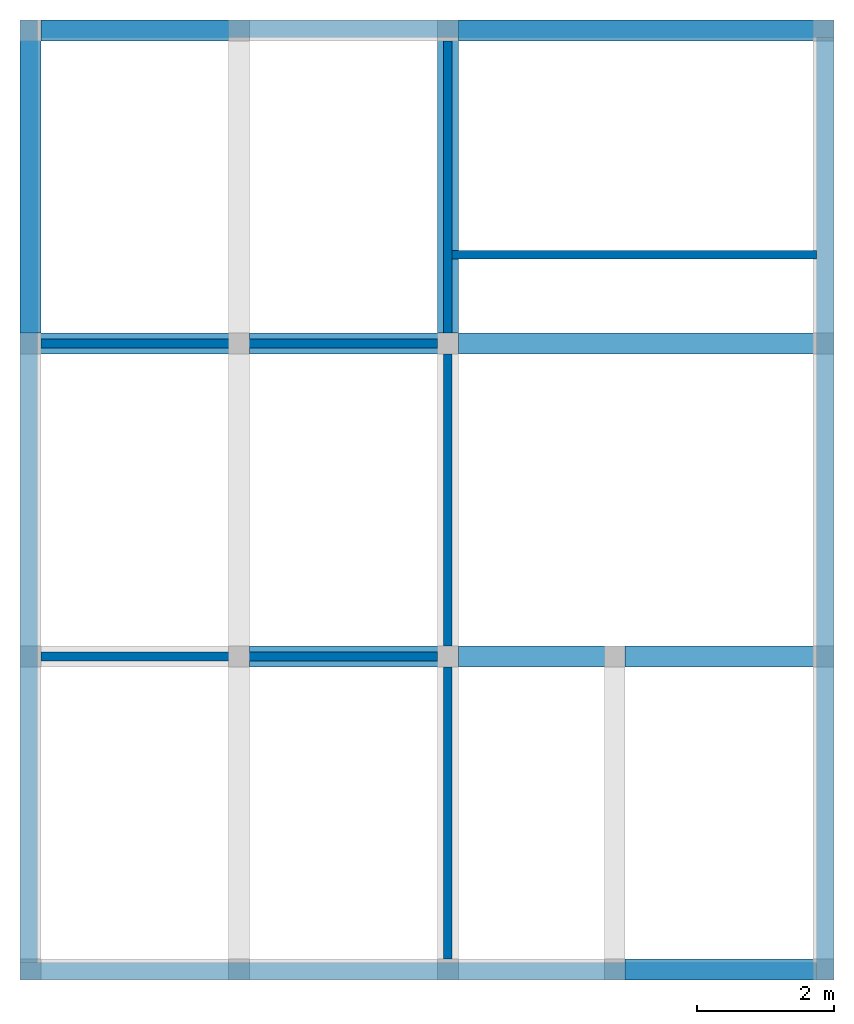
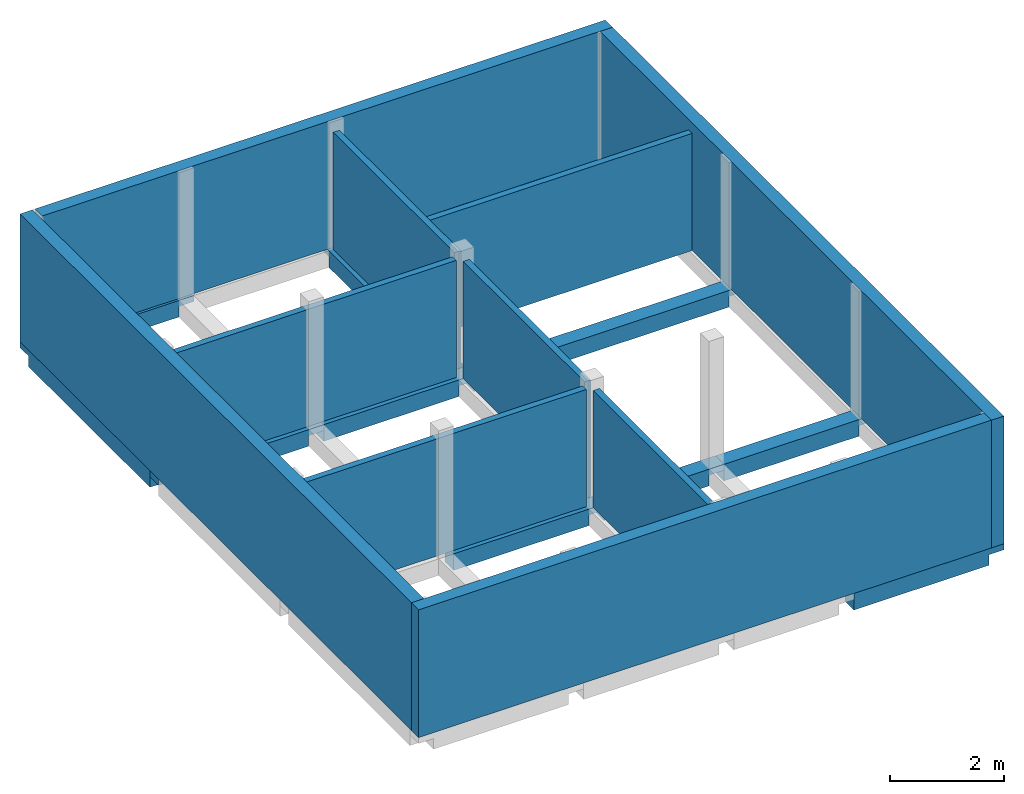
# One storey, part 2 of 2: 11 beams, 10 walls.
"""IFC2X3 building model written with IfcOpenShell, lengths in feet."""

from ifc_helpers import new_model, entity, si_unit, converted_unit, derived_unit, direction, frame, frame_2d, origin, place, context, subcontext, project, spatial, rectangle, extrude, faceted_brep, material, layer, layer_set, layer_usage, type_object, element, save


model = new_model("IFC2X3")

# Units and contexts
model_context = context("Model", 3, precision=0.0001, world=origin(), true_north=direction((6.123031769111886e-17, 1.0)))
body_context = subcontext(model_context, "Body", "Model", "MODEL_VIEW")
ifc_project = project(units=[converted_unit("LENGTHUNIT", "FOOT", entity("IfcLengthMeasure", 0.3048), si_unit("LENGTHUNIT", "METRE"), dimensions=[1, 0, 0, 0, 0, 0, 0]), converted_unit("AREAUNIT", "SQUARE FOOT", entity("IfcAreaMeasure", 0.09290304), si_unit("AREAUNIT", "SQUARE_METRE"), dimensions=[2, 0, 0, 0, 0, 0, 0]), converted_unit("VOLUMEUNIT", "CUBIC FOOT", entity("IfcVolumeMeasure", 0.028316846592000004), si_unit("VOLUMEUNIT", "CUBIC_METRE"), dimensions=[3, 0, 0, 0, 0, 0, 0]), converted_unit("PLANEANGLEUNIT", "DEGREE", entity("IfcPlaneAngleMeasure", 0.017453292519943278), si_unit("PLANEANGLEUNIT", "RADIAN"), dimensions=[0, 0, 0, 0, 0, 0, 0]), si_unit("MASSUNIT", "GRAM", prefix="KILO"), derived_unit("MASSDENSITYUNIT", [(si_unit("MASSUNIT", "GRAM", prefix="KILO"), 1), (si_unit("LENGTHUNIT", "METRE"), -3)]), derived_unit("IONCONCENTRATIONUNIT", [(si_unit("MASSUNIT", "GRAM", prefix="KILO"), 1), (si_unit("LENGTHUNIT", "METRE"), -3)]), derived_unit("MOMENTOFINERTIAUNIT", [(si_unit("LENGTHUNIT", "METRE"), 4)]), si_unit("TIMEUNIT", "SECOND"), si_unit("FREQUENCYUNIT", "HERTZ"), si_unit("THERMODYNAMICTEMPERATUREUNIT", "DEGREE_CELSIUS"), derived_unit("THERMALTRANSMITTANCEUNIT", [(si_unit("MASSUNIT", "GRAM", prefix="KILO"), 1), (si_unit("THERMODYNAMICTEMPERATUREUNIT", "KELVIN"), -1), (si_unit("TIMEUNIT", "SECOND"), -3)]), derived_unit("THERMALCONDUCTANCEUNIT", [(si_unit("MASSUNIT", "GRAM", prefix="KILO"), 1), (si_unit("THERMODYNAMICTEMPERATUREUNIT", "KELVIN"), -1), (si_unit("TIMEUNIT", "SECOND"), -3), (si_unit("LENGTHUNIT", "METRE"), 1)]), derived_unit("VOLUMETRICFLOWRATEUNIT", [(si_unit("LENGTHUNIT", "METRE"), 3), (si_unit("TIMEUNIT", "SECOND"), -1)]), derived_unit("MASSFLOWRATEUNIT", [(si_unit("MASSUNIT", "GRAM", prefix="KILO"), 1), (si_unit("TIMEUNIT", "SECOND"), -1)]), derived_unit("ROTATIONALFREQUENCYUNIT", [(si_unit("TIMEUNIT", "SECOND"), -1)]), si_unit("ELECTRICCURRENTUNIT", "AMPERE"), si_unit("ELECTRICVOLTAGEUNIT", "VOLT"), si_unit("POWERUNIT", "WATT"), converted_unit("FORCEUNIT", "KIP", entity("IfcForceMeasure", 2.088543423315013e-05), si_unit("FORCEUNIT", "NEWTON"), dimensions=[1, 1, -2, 0, 0, 0, 0]), si_unit("ILLUMINANCEUNIT", "LUX"), si_unit("LUMINOUSFLUXUNIT", "LUMEN"), si_unit("LUMINOUSINTENSITYUNIT", "CANDELA"), si_unit("ENERGYUNIT", "JOULE"), derived_unit("USERDEFINED", [(si_unit("MASSUNIT", "GRAM", prefix="KILO"), -1), (si_unit("LENGTHUNIT", "METRE"), -2), (si_unit("TIMEUNIT", "SECOND"), 3), (si_unit("LUMINOUSFLUXUNIT", "LUMEN"), 1)]), derived_unit("USERDEFINED", [(si_unit("MASSUNIT", "GRAM", prefix="KILO"), 1), (si_unit("TIMEUNIT", "SECOND"), -3), (si_unit("LENGTHUNIT", "METRE"), 3), (si_unit("ELECTRICCURRENTUNIT", "AMPERE"), -2)]), derived_unit("SOUNDPOWERUNIT", [(si_unit("MASSUNIT", "GRAM", prefix="KILO"), 1), (si_unit("TIMEUNIT", "SECOND"), -3), (si_unit("LENGTHUNIT", "METRE"), 2)]), derived_unit("SOUNDPRESSUREUNIT", [(si_unit("MASSUNIT", "GRAM", prefix="KILO"), 1), (si_unit("LENGTHUNIT", "METRE"), -1), (si_unit("TIMEUNIT", "SECOND"), -2)]), derived_unit("LINEARVELOCITYUNIT", [(si_unit("LENGTHUNIT", "METRE"), 1), (si_unit("TIMEUNIT", "SECOND"), -1)]), si_unit("PRESSUREUNIT", "PASCAL"), derived_unit("USERDEFINED", [(si_unit("MASSUNIT", "GRAM", prefix="KILO"), 1), (si_unit("LENGTHUNIT", "METRE"), -2), (si_unit("TIMEUNIT", "SECOND"), -2)]), derived_unit("LINEARFORCEUNIT", [(si_unit("MASSUNIT", "GRAM", prefix="KILO"), 1), (si_unit("TIMEUNIT", "SECOND"), -2)]), derived_unit("PLANARFORCEUNIT", [(si_unit("MASSUNIT", "GRAM", prefix="KILO"), 1), (si_unit("LENGTHUNIT", "METRE"), -1), (si_unit("TIMEUNIT", "SECOND"), -2)]), derived_unit("SPECIFICHEATCAPACITYUNIT", [(si_unit("THERMODYNAMICTEMPERATUREUNIT", "KELVIN"), -1), (si_unit("LENGTHUNIT", "METRE"), 2), (si_unit("TIMEUNIT", "SECOND"), -2)]), derived_unit("HEATFLUXDENSITYUNIT", [(si_unit("MASSUNIT", "GRAM", prefix="KILO"), 1), (si_unit("TIMEUNIT", "SECOND"), -3)]), derived_unit("HEATINGVALUEUNIT", [(si_unit("LENGTHUNIT", "METRE"), 2), (si_unit("TIMEUNIT", "SECOND"), -2)]), derived_unit("VAPORPERMEABILITYUNIT", [(si_unit("LENGTHUNIT", "METRE"), -1), (si_unit("TIMEUNIT", "SECOND"), 1)]), derived_unit("DYNAMICVISCOSITYUNIT", [(si_unit("MASSUNIT", "GRAM", prefix="KILO"), 1), (si_unit("TIMEUNIT", "SECOND"), -1), (si_unit("LENGTHUNIT", "METRE"), -1)]), derived_unit("THERMALEXPANSIONCOEFFICIENTUNIT", [(si_unit("THERMODYNAMICTEMPERATUREUNIT", "KELVIN"), -1)]), derived_unit("MODULUSOFELASTICITYUNIT", [(si_unit("MASSUNIT", "GRAM", prefix="KILO"), 1), (si_unit("LENGTHUNIT", "METRE"), -1), (si_unit("TIMEUNIT", "SECOND"), -2)]), derived_unit("ISOTHERMALMOISTURECAPACITYUNIT", [(si_unit("LENGTHUNIT", "METRE"), 3), (si_unit("MASSUNIT", "GRAM", prefix="KILO"), -1)]), derived_unit("MOISTUREDIFFUSIVITYUNIT", [(si_unit("TIMEUNIT", "SECOND"), -1), (si_unit("LENGTHUNIT", "METRE"), 2)]), derived_unit("MASSPERLENGTHUNIT", [(si_unit("MASSUNIT", "GRAM", prefix="KILO"), 1), (si_unit("LENGTHUNIT", "METRE"), -1)]), derived_unit("THERMALRESISTANCEUNIT", [(si_unit("MASSUNIT", "GRAM", prefix="KILO"), -1), (si_unit("TIMEUNIT", "SECOND"), 3), (si_unit("THERMODYNAMICTEMPERATUREUNIT", "KELVIN"), 1)]), derived_unit("ACCELERATIONUNIT", [(si_unit("LENGTHUNIT", "METRE"), 1), (si_unit("TIMEUNIT", "SECOND"), -2)]), derived_unit("ANGULARVELOCITYUNIT", [(si_unit("TIMEUNIT", "SECOND"), -1), (si_unit("PLANEANGLEUNIT", "RADIAN"), 1)]), derived_unit("LINEARSTIFFNESSUNIT", [(si_unit("MASSUNIT", "GRAM", prefix="KILO"), 1), (si_unit("TIMEUNIT", "SECOND"), -2)]), derived_unit("WARPINGCONSTANTUNIT", [(si_unit("LENGTHUNIT", "METRE"), 6)]), derived_unit("LINEARMOMENTUNIT", [(si_unit("MASSUNIT", "GRAM", prefix="KILO"), 1), (si_unit("LENGTHUNIT", "METRE"), 1), (si_unit("TIMEUNIT", "SECOND"), -2)]), derived_unit("TORQUEUNIT", [(si_unit("MASSUNIT", "GRAM", prefix="KILO"), 1), (si_unit("LENGTHUNIT", "METRE"), 2), (si_unit("TIMEUNIT", "SECOND"), -2)])], contexts=[model_context])

# Site, building, storey
site_placement = place(None, origin())
site = spatial("IfcSite", under=ifc_project, at=site_placement, CompositionType="ELEMENT")
building_placement = place(site_placement, origin())
building = spatial("IfcBuilding", under=site, at=building_placement, CompositionType="ELEMENT")
storey_placement = place(building_placement, frame((0.0, 0.0, 9.416666666668288)))
storey = spatial("IfcBuildingStorey", under=building, at=storey_placement, Name="First Floor", CompositionType="ELEMENT", Elevation=9.416666666668288)

# Beams
ifc_material_1 = material(Name="Concrete, Cast-in-Place gray")
beam_type = type_object("IfcBeamType", PredefinedType="NOTDEFINED")
for number, where in (
    (1, (38.37447801916311, -50.34124484724908, -1.1666666666666714)),
    (2, (20.374478019163327, -35.34124484724902, -1.1666666666666714)),
):
    element("IfcBeam", number, at=place(storey_placement, frame(where)), inside=storey, type_object=beam_type, material=ifc_material_1, context=body_context, shape_type="Brep", body=[
        faceted_brep([(10.0, 0.0, 1.1666666666666643), (10.0, 1.0, 1.1666666666666643), (9.0, 1.0, 1.1666666666666643), (0.0, 1.0, 1.1666666666666643), (0.0, 0.0, 1.1666666666666643), (9.0, 0.0, 1.1666666666666643), (0.0, 0.0, 0.7499999999983835), (0.0, 0.0, 0.0), (9.0, 0.0, 0.0), (9.0, 0.0, 0.7499999999983835), (10.0, 0.0, 0.7499999999983835), (0.0, 1.0, 0.0), (9.0, 1.0, 0.0), (10.0, 1.0, 0.7499999999983835), (9.0, 1.0, 0.7499999999983835), (0.0, 1.0, 0.7499999999983835)], [[[0, 1, 2, 3, 4, 5]], [[0, 5, 4, 6, 7, 8, 9, 10]], [[7, 11, 12, 8]], [[3, 2, 1, 13, 14, 12, 11, 15]], [[1, 0, 10, 13]], [[4, 3, 15, 11, 7, 6]], [[14, 9, 8, 12]], [[9, 14, 13, 10]]]),
    ])
beam_1_placement = place(storey_placement, frame((30.37447801916315, -35.34124484724903, -1.1666666666666732)))
element("IfcBeam", 3, at=beam_1_placement, inside=storey, type_object=beam_type, material=ifc_material_1, context=body_context, shape_type="Brep", body=[
    faceted_brep([(8.0, 0.0, 1.166666666666666), (8.0, 1.0, 1.166666666666666), (7.0, 1.0, 1.166666666666666), (0.0, 1.0, 1.166666666666666), (0.0, 0.0, 1.1666666666666679), (7.0, 0.0, 1.1666666666666679), (0.0, 0.0, 0.7499999999983853), (0.0, 0.0, 0.0), (7.0, 0.0, 0.0), (7.0, 0.0, 0.7499999999983853), (8.0, 0.0, 0.7499999999983853), (0.0, 1.0, 0.0), (7.0, 1.0, 0.0), (8.0, 1.0, 0.7499999999983853), (7.0, 1.0, 0.7499999999983853), (0.0, 1.0, 0.7499999999983853)], [[[0, 1, 2, 3, 4, 5]], [[0, 5, 4, 6, 7, 8, 9, 10]], [[7, 11, 12, 8]], [[3, 2, 1, 13, 14, 12, 11, 15]], [[1, 0, 10, 13]], [[4, 3, 15, 11, 7, 6]], [[14, 9, 8, 12]], [[9, 14, 13, 10]]]),
])
beam_2_placement = place(storey_placement, frame((38.37447801916313, -35.34124484724908, -1.1666666666666714)))
element("IfcBeam", 4, at=beam_2_placement, inside=storey, type_object=beam_type, material=ifc_material_1, context=body_context, shape_type="Brep", body=[
    faceted_brep([(10.0, 0.0, 1.1666666666666643), (10.0, 1.0, 1.1666666666666643), (9.0, 1.0, 1.1666666666666643), (0.0, 1.0, 1.1666666666666643), (0.0, 0.0, 1.1666666666666643), (9.0, 0.0, 1.1666666666666643), (0.0, 0.0, 0.7499999999983835), (0.0, 0.0, 0.0), (9.0, 0.0, 0.0), (9.0, 0.0, 0.7499999999983835), (10.0, 0.0, 0.7499999999983835), (0.0, 1.0, 0.0), (9.0, 1.0, 0.0), (10.0, 1.0, 0.7499999999983835), (9.0, 1.0, 0.7499999999983835), (0.0, 1.0, 0.7499999999983835)], [[[0, 1, 2, 3, 4, 5]], [[0, 5, 4, 6, 7, 8, 9, 10]], [[7, 11, 12, 8]], [[3, 2, 1, 13, 14, 12, 11, 15]], [[1, 0, 10, 13]], [[4, 3, 15, 11, 7, 6]], [[14, 9, 8, 12]], [[9, 14, 13, 10]]]),
])
beam_3_placement = place(storey_placement, frame((9.374478019163147, -20.341244847248984, -1.1666666666666714)))
element("IfcBeam", 5, at=beam_3_placement, inside=storey, type_object=beam_type, material=ifc_material_1, context=body_context, shape_type="Brep", body=[
    faceted_brep([(11.0, 0.0, 1.1666666666666643), (11.0, 1.0, 1.1666666666666643), (10.0, 1.0, 1.1666666666666643), (1.0, 1.0, 1.1666666666666643), (0.0, 1.0, 1.1666666666666643), (0.0, 0.0, 1.1666666666666643), (1.0, 0.0, 1.1666666666666643), (10.0, 0.0, 1.1666666666666643), (0.0, 0.0, 0.7499999999983835), (1.0, 0.0, 0.7499999999983835), (1.0, 0.0, 0.0), (10.0, 0.0, 0.0), (10.0, 0.0, 0.7499999999983835), (11.0, 0.0, 0.7499999999983835), (1.0, 1.0, 0.0), (10.0, 1.0, 0.0), (11.0, 1.0, 0.7499999999983835), (10.0, 1.0, 0.7499999999983835), (1.0, 1.0, 0.7499999999983835), (0.0, 1.0, 0.7499999999983835)], [[[0, 1, 2, 3, 4, 5, 6, 7]], [[0, 7, 6, 5, 8, 9, 10, 11, 12, 13]], [[10, 14, 15, 11]], [[4, 3, 2, 1, 16, 17, 15, 14, 18, 19]], [[1, 0, 13, 16]], [[5, 4, 19, 8]], [[9, 18, 14, 10]], [[18, 9, 8, 19]], [[17, 12, 11, 15]], [[12, 17, 16, 13]]]),
])
beam_4_placement = place(storey_placement, frame((20.374478019163355, -20.341244847249012, -1.1666666666666714)))
element("IfcBeam", 6, at=beam_4_placement, inside=storey, type_object=beam_type, material=ifc_material_1, context=body_context, shape_type="Brep", body=[
    faceted_brep([(10.0, 0.0, 1.1666666666666643), (10.0, 1.0, 1.1666666666666643), (9.0, 1.0, 1.1666666666666643), (0.0, 1.0, 1.1666666666666643), (0.0, 0.0, 1.1666666666666643), (9.0, 0.0, 1.1666666666666643), (0.0, 0.0, 0.7499999999983835), (0.0, 0.0, 0.0), (9.0, 0.0, 0.0), (9.0, 0.0, 0.7499999999983835), (10.0, 0.0, 0.7499999999983835), (0.0, 1.0, 0.0), (9.0, 1.0, 0.0), (10.0, 1.0, 0.7499999999983835), (9.0, 1.0, 0.7499999999983835), (0.0, 1.0, 0.7499999999983835)], [[[0, 1, 2, 3, 4, 5]], [[0, 5, 4, 6, 7, 8, 9, 10]], [[7, 11, 12, 8]], [[3, 2, 1, 13, 14, 12, 11, 15]], [[1, 0, 10, 13]], [[4, 3, 15, 11, 7, 6]], [[14, 9, 8, 12]], [[9, 14, 13, 10]]]),
])
beam_5_placement = place(storey_placement, frame((30.374478019163178, -20.341244847249072, -1.1666666666666732)))
element("IfcBeam", 7, at=beam_5_placement, inside=storey, type_object=beam_type, material=ifc_material_1, context=body_context, shape_type="Brep", body=[
    faceted_brep([(18.0, 0.0, 1.166666666666666), (18.0, 1.0, 1.166666666666666), (17.0, 1.0, 1.166666666666666), (0.0, 1.0, 1.166666666666666), (0.0, 0.0, 1.1666666666666679), (17.0, 0.0, 1.1666666666666679), (0.0, 0.0, 0.7499999999983853), (0.0, 0.0, 0.0), (17.0, 0.0, 0.0), (17.0, 0.0, 0.7499999999983853), (18.0, 0.0, 0.7499999999983853), (0.0, 1.0, 0.0), (17.0, 1.0, 0.0), (18.0, 1.0, 0.7499999999983853), (17.0, 1.0, 0.7499999999983853), (0.0, 1.0, 0.7499999999983853)], [[[0, 1, 2, 3, 4, 5]], [[0, 5, 4, 6, 7, 8, 9, 10]], [[7, 11, 12, 8]], [[3, 2, 1, 13, 14, 12, 11, 15]], [[1, 0, 10, 13]], [[4, 3, 15, 11, 7, 6]], [[14, 9, 8, 12]], [[9, 14, 13, 10]]]),
])
for number, where, z_axis, x_axis in (
    (8, (9.374478019162256, -19.34124484724894, -1.1666666666666732), (0.0, 0.0, 1.0), (0.0, -1.0, 0.0)),
    (9, (29.374478019162254, -19.341244847249, -1.1666666666666732), (0.0, 0.0, 1.0), (0.0, -1.0, 0.0)),
):
    element("IfcBeam", number, at=place(storey_placement, frame(where, z_axis=z_axis, x_axis=x_axis)), inside=storey, type_object=beam_type, material=ifc_material_1, context=body_context, shape_type="Brep", body=[
        faceted_brep([(-15.0, 1.0, 1.166666666666666), (-15.0, 0.0, 1.1666666666666679), (-14.0, 0.0, 1.1666666666666679), (0.0, 0.0, 1.166666666666666), (0.0, 1.0, 1.166666666666666), (-14.0, 1.0, 1.166666666666666), (-15.0, 0.0, 0.7499999999983853), (-14.0, 0.0, 0.7499999999983853), (-14.0, 0.0, 0.0), (0.0, 0.0, 0.0), (0.0, 0.0, 0.7499999999983853), (0.0, 1.0, 0.0), (-14.0, 1.0, 0.0), (0.0, 1.0, 0.7499999999983853), (-14.0, 1.0, 0.7499999999983853), (-15.0, 1.0, 0.7499999999983853)], [[[0, 1, 2, 3, 4, 5]], [[3, 2, 1, 6, 7, 8, 9, 10]], [[11, 9, 8, 12]], [[0, 5, 4, 13, 11, 12, 14, 15]], [[1, 0, 15, 6]], [[4, 3, 10, 9, 11, 13]], [[7, 14, 12, 8]], [[14, 7, 6, 15]]]),
    ])
beam_6_placement = place(storey_placement, frame((10.374478019163183, -5.341244847248929, -1.1666666666666714)))
element("IfcBeam", 10, at=beam_6_placement, inside=storey, type_object=beam_type, material=ifc_material_1, context=body_context, shape_type="Brep", body=[
    faceted_brep([(10.0, 0.0, 1.1666666666666643), (10.0, 1.0, 1.1666666666666643), (9.0, 1.0, 1.1666666666666643), (0.0, 1.0, 1.1666666666666643), (0.0, 0.0, 1.1666666666666643), (9.0, 0.0, 1.1666666666666643), (0.0, 0.0, 0.7499999999983835), (0.0, 0.0, 0.0), (9.0, 0.0, 0.0), (9.0, 0.0, 0.7499999999983835), (10.0, 0.0, 0.7499999999983835), (0.0, 1.0, 0.0), (9.0, 1.0, 0.0), (10.0, 1.0, 0.7499999999983835), (9.0, 1.0, 0.7499999999983835), (0.0, 1.0, 0.7499999999983835)], [[[0, 1, 2, 3, 4, 5]], [[0, 5, 4, 6, 7, 8, 9, 10]], [[7, 11, 12, 8]], [[3, 2, 1, 13, 14, 12, 11, 15]], [[1, 0, 10, 13]], [[4, 3, 15, 11, 7, 6]], [[14, 9, 8, 12]], [[9, 14, 13, 10]]]),
])
beam_7_placement = place(storey_placement, frame((30.374478019163202, -5.341244847249021, -1.1666666666666732)))
element("IfcBeam", 11, at=beam_7_placement, inside=storey, type_object=beam_type, material=ifc_material_1, context=body_context, shape_type="Brep", body=[
    faceted_brep([(18.0, 0.0, 1.166666666666666), (18.0, 1.0, 1.166666666666666), (17.0, 1.0, 1.166666666666666), (0.0, 1.0, 1.166666666666666), (0.0, 0.0, 1.1666666666666679), (17.0, 0.0, 1.1666666666666679), (0.0, 0.0, 0.7499999999983853), (0.0, 0.0, 0.0), (17.0, 0.0, 0.0), (17.0, 0.0, 0.7499999999983853), (18.0, 0.0, 0.7499999999983853), (0.0, 1.0, 0.0), (17.0, 1.0, 0.0), (18.0, 1.0, 0.7499999999983853), (17.0, 1.0, 0.7499999999983853), (0.0, 1.0, 0.7499999999983853)], [[[0, 1, 2, 3, 4, 5]], [[0, 5, 4, 6, 7, 8, 9, 10]], [[7, 11, 12, 8]], [[3, 2, 1, 13, 14, 12, 11, 15]], [[1, 0, 10, 13]], [[4, 3, 15, 11, 7, 6]], [[14, 9, 8, 12]], [[9, 14, 13, 10]]]),
])

# Walls
ifc_material_2 = material(Name="Default Wall")
ifc_layer_1 = layer(ifc_material_2, 0.041666666666666664)
ifc_layer_2 = layer(ifc_material_2, 0.75)
ifc_layer_3 = layer(ifc_material_2, 0.041666666666666664)
ifc_layer_set_1 = layer_set([ifc_layer_1, ifc_layer_2, ifc_layer_3])
ifc_layer_usage_1 = layer_usage(ifc_layer_set_1, "AXIS2", "NEGATIVE", 0.4166666666666667)
wall_type_1 = type_object("IfcWallType", PredefinedType="STANDARD", material=ifc_layer_set_1)
wall_1_placement = place(storey_placement, frame((10.37447801916223, -4.757911513915553, 0.0)))
element("IfcWallStandardCase", 12, at=wall_1_placement, inside=storey, type_object=wall_type_1, material=ifc_layer_usage_1, context=body_context, shape_type="SweptSolid", body=[
    extrude(rectangle(XDim=38.00000000000001, YDim=0.8333333333333339, at=frame_2d((19.000000000000004, 0.0), x_axis=(-1.0, 0.0))), origin(), (0.0, 0.0, 1.0), 8.999999999998618),
])
wall_2_placement = place(storey_placement, frame((47.957811352495575, -5.174578180582336, 0.0), z_axis=(0.0, 0.0, 1.0), x_axis=(0.0, -1.0, 0.0)))
element("IfcWallStandardCase", 13, at=wall_2_placement, inside=storey, type_object=wall_type_1, material=ifc_layer_usage_1, context=body_context, shape_type="SweptSolid", body=[
    extrude(rectangle(XDim=45.16666666666672, YDim=0.8333333333333286, at=frame_2d((22.58333333333336, -6.38378239159465e-16), x_axis=(-1.0, 0.0))), origin(), (0.0, 0.0, 1.0), 8.999999999998618),
])
wall_3_placement = place(storey_placement, frame((47.54114468582883, -49.924578180582394, 0.0), z_axis=(0.0, 0.0, 1.0), x_axis=(-1.0, 0.0, 0.0)))
element("IfcWallStandardCase", 14, at=wall_3_placement, inside=storey, type_object=wall_type_1, material=ifc_layer_usage_1, context=body_context, shape_type="SweptSolid", body=[
    extrude(rectangle(XDim=38.16666666666667, YDim=0.8333333333333286, at=frame_2d((19.083333333333336, -1.3600232051658168e-15), x_axis=(-1.0, 0.0))), origin(), (0.0, 0.0, 1.0), 8.999999999998618),
])
wall_4_placement = place(storey_placement, frame((9.79114468582883, -49.507911513915595, 0.0), z_axis=(0.0, 0.0, 1.0), x_axis=(0.0, 1.0, 0.0)))
element("IfcWallStandardCase", 15, at=wall_4_placement, inside=storey, type_object=wall_type_1, material=ifc_layer_usage_1, context=body_context, shape_type="SweptSolid", body=[
    extrude(rectangle(XDim=45.166666666666714, YDim=0.8333333333333321, at=frame_2d((22.583333333333357, 2.220446049250313e-16), x_axis=(-1.0, 0.0))), origin(), (0.0, 0.0, 1.0), 8.999999999998618),
])
ifc_layer_4 = layer(ifc_material_2, 0.4166666666666667)
ifc_layer_set_2 = layer_set([ifc_layer_4])
ifc_layer_usage_2 = layer_usage(ifc_layer_set_2, "AXIS2", "NEGATIVE", 0.20833333333333334)
wall_type_2 = type_object("IfcWallType", PredefinedType="STANDARD", material=ifc_layer_set_2)
wall_5_placement = place(storey_placement, frame((10.37447801916221, -19.841244847248937, 0.0)))
element("IfcWallStandardCase", 16, at=wall_5_placement, inside=storey, type_object=wall_type_2, material=ifc_layer_usage_2, context=body_context, shape_type="SweptSolid", body=[
    extrude(rectangle(XDim=19.0, YDim=0.4166666666666643, at=frame_2d((9.5, 0.0), x_axis=(-1.0, 0.0))), origin(), (0.0, 0.0, 1.0), 8.249999999998618),
])
wall_6_placement = place(storey_placement, frame((29.87447801916221, -19.341244847248994, 0.0), z_axis=(0.0, 0.0, 1.0), x_axis=(0.0, 1.0, 0.0)))
element("IfcWallStandardCase", 17, at=wall_6_placement, inside=storey, type_object=wall_type_2, material=ifc_layer_usage_2, context=body_context, shape_type="SweptSolid", body=[
    extrude(rectangle(XDim=14.000000000000046, YDim=0.4166666666666643, at=frame_2d((7.000000000000023, 0.0), x_axis=(-1.0, 0.0))), origin(), (0.0, 0.0, 1.0), 8.249999999998618),
])
wall_7_placement = place(storey_placement, frame((29.87447801916221, -20.341244847249, 0.0), z_axis=(0.0, 0.0, 1.0), x_axis=(0.0, -1.0, 0.0)))
element("IfcWallStandardCase", 18, at=wall_7_placement, inside=storey, type_object=wall_type_2, material=ifc_layer_usage_2, context=body_context, shape_type="SweptSolid", body=[
    extrude(rectangle(XDim=13.999999999999986, YDim=0.4166666666666643, at=frame_2d((6.999999999999993, 0.0), x_axis=(-1.0, 0.0))), origin(), (0.0, 0.0, 1.0), 8.249999999998618),
])
wall_8_placement = place(storey_placement, frame((29.37447801916219, -34.841244847248994, 0.0), z_axis=(0.0, 0.0, 1.0), x_axis=(-1.0, 0.0, 0.0)))
element("IfcWallStandardCase", 19, at=wall_8_placement, inside=storey, type_object=wall_type_2, material=ifc_layer_usage_2, context=body_context, shape_type="SweptSolid", body=[
    extrude(rectangle(XDim=19.000000000000007, YDim=0.4166666666666714, at=frame_2d((9.500000000000004, 0.0), x_axis=(-1.0, 0.0))), origin(), (0.0, 0.0, 1.0), 8.249999999998618),
])
wall_9_placement = place(storey_placement, frame((29.87447801916219, -35.341244847249, 0.0), z_axis=(0.0, 0.0, 1.0), x_axis=(0.0, -1.0, 0.0)))
element("IfcWallStandardCase", 20, at=wall_9_placement, inside=storey, type_object=wall_type_2, material=ifc_layer_usage_2, context=body_context, shape_type="SweptSolid", body=[
    extrude(rectangle(XDim=13.999999999999986, YDim=0.4166666666666643, at=frame_2d((6.999999999999993, 0.0), x_axis=(-1.0, 0.0))), origin(), (0.0, 0.0, 1.0), 8.249999999998618),
])
wall_10_placement = place(storey_placement, frame((30.082811352495554, -15.591244847248992, 0.0)))
element("IfcWallStandardCase", 21, at=wall_10_placement, inside=storey, type_object=wall_type_2, material=ifc_layer_usage_2, context=body_context, shape_type="SweptSolid", body=[
    extrude(rectangle(XDim=17.458333333333336, YDim=0.41666666666666785, at=frame_2d((8.729166666666668, -1.3877787807814457e-16), x_axis=(-1.0, 0.0))), origin(), (0.0, 0.0, 1.0), 8.249999999998618),
])

save(model, "model.ifc")
